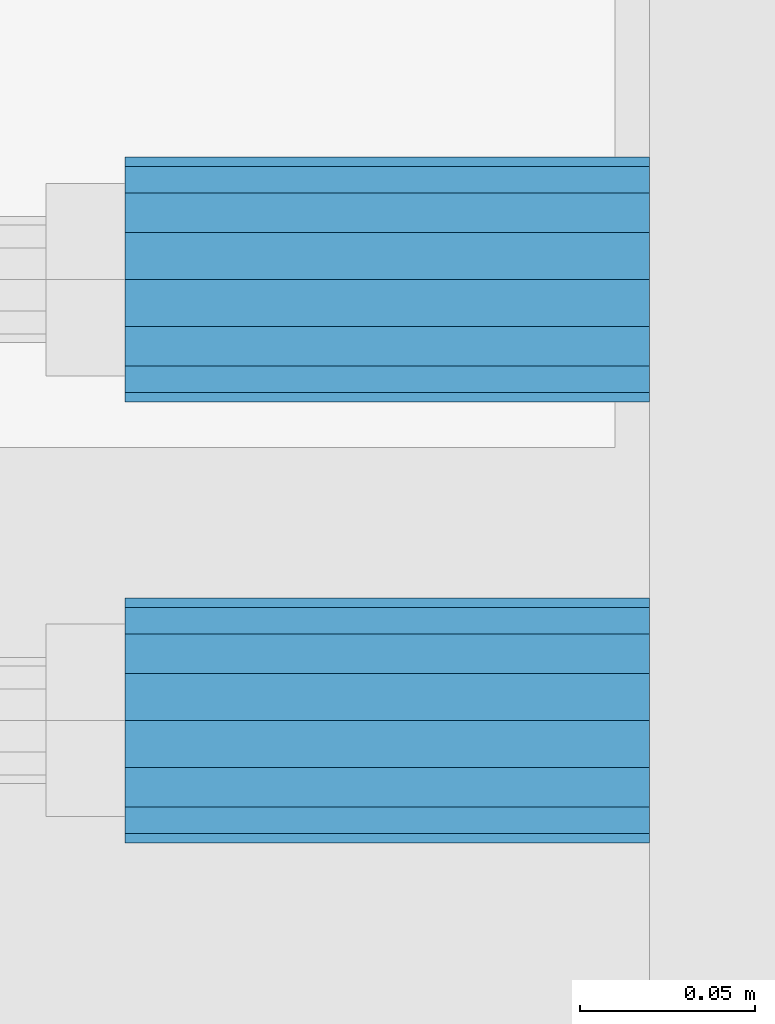
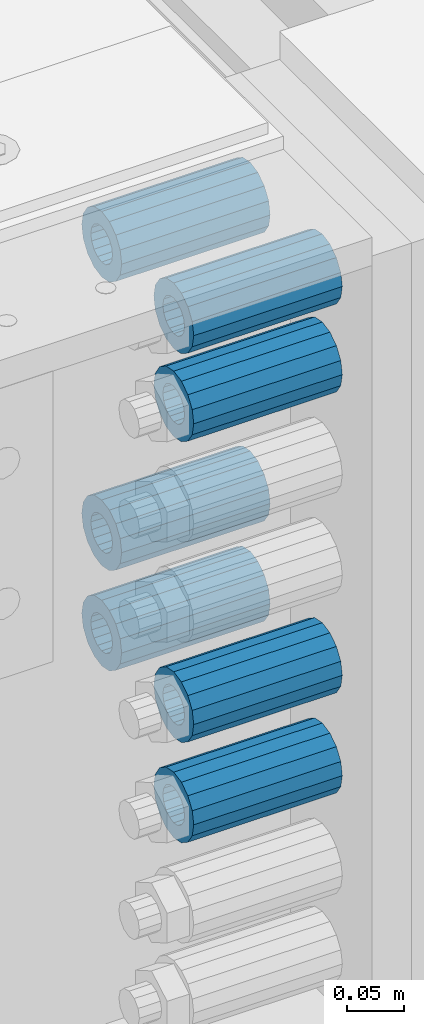
# One storey, part 160 of 257: 7 beams.
"""IFC2X3 building model written with IfcOpenShell, lengths in millimetres."""

from ifc_helpers import new_model, si_unit, frame, origin_with_axes, place, context, subcontext, project, spatial, faceted_brep, material, type_object, element, save


model = new_model("IFC2X3")

# Units and contexts
model_context = context("Model", 3, precision=1e-05, world=origin_with_axes())
body_context = subcontext(model_context, "Body", "Model", "MODEL_VIEW")
ifc_project = project(units=[si_unit("LENGTHUNIT", "METRE", prefix="MILLI"), si_unit("AREAUNIT", "SQUARE_METRE"), si_unit("VOLUMEUNIT", "CUBIC_METRE"), si_unit("MASSUNIT", "GRAM", prefix="KILO"), si_unit("TIMEUNIT", "SECOND"), si_unit("PLANEANGLEUNIT", "RADIAN"), si_unit("SOLIDANGLEUNIT", "STERADIAN"), si_unit("THERMODYNAMICTEMPERATUREUNIT", "DEGREE_CELSIUS"), si_unit("LUMINOUSINTENSITYUNIT", "LUMEN")], contexts=[model_context])

# Site, building, storey
site_placement = place(None, origin_with_axes())
site = spatial("IfcSite", under=ifc_project, at=site_placement, CompositionType="ELEMENT")
building_placement = place(site_placement, origin_with_axes())
building = spatial("IfcBuilding", under=site, at=building_placement, Name="Standard", CompositionType="ELEMENT")
storey_placement = place(building_placement, origin_with_axes())
storey = spatial("IfcBuildingStorey", under=building, at=storey_placement, Name="Undefined", CompositionType="ELEMENT", Elevation=0.0)

# Beams
ifc_material = material()
beam_type = type_object("IfcBeamType", PredefinedType="NOTDEFINED")
beam_1_placement = place(storey_placement, frame((59117.0, -63.0, -499.0), z_axis=(0.0, 0.0, 1.0), x_axis=(1.0, 0.0, 0.0)))
element("IfcBeam", 1, at=beam_1_placement, inside=storey, type_object=beam_type, material=ifc_material, context=body_context, shape_type="Brep", body=[
    faceted_brep([(-1.3120632047503e-07, -18.9999999995493, -6.27187546342611e-09), (0.0, -17.5537111177146, 7.27098521493672), (150.0, -17.5537111177146, 7.27098521493672), (150.0, -19.0, 0.0), (0.0, -13.4350288425449, 13.4350288425444), (150.0, -13.4350288425449, 13.4350288425444), (0.0, -7.27098521493645, 17.5537111177144), (150.0, -7.27098521493645, 17.5537111177144), (-6.33792751614237e-09, 4.50654624728486e-10, 18.9999999937208), (150.0, 0.0, 19.0), (0.0, 7.27098521493645, 17.5537111177144), (150.0, 7.27098521493645, 17.5537111177144), (0.0, 13.4350288425449, 13.4350288425444), (150.0, 13.4350288425449, 13.4350288425444), (0.0, 17.5537111177146, 7.2709852149367), (150.0, 17.5537111177146, 7.2709852149367), (1.33208345687308e-07, 19.0000000004507, -6.27187546342611e-09), (150.0, 19.0, 0.0), (0.0, 17.5537111177146, -7.2709852149367), (150.0, 17.5537111177146, -7.2709852149367), (0.0, 13.4350288425449, -13.4350288425444), (150.0, 13.4350288425449, -13.4350288425444), (0.0, 7.27098521493645, -17.5537111177144), (150.0, 7.27098521493645, -17.5537111177144), (8.33983904158231e-09, 4.50654624728486e-10, -19.0000000062719), (150.0, 0.0, -19.0), (0.0, -7.27098521493645, -17.5537111177144), (150.0, -7.27098521493645, -17.5537111177144), (0.0, -13.4350288425449, -13.4350288425444), (150.0, -13.4350288425449, -13.4350288425444), (0.0, -17.5537111177146, -7.2709852149367), (150.0, -17.5537111177146, -7.2709852149367), (7.27595761418343e-12, -35.0, 0.0), (1.45519152283669e-11, -32.335783637895, -13.3939201327781), (150.0, -32.3357836378955, -13.3939201327782), (150.0, -35.0, 0.0), (7.27595761418343e-12, -24.7487373415292, -24.748737341529), (150.0, -24.7487373415288, -24.7487373415292), (7.27595761418343e-12, -13.3939201327781, -32.335783637895), (150.0, -13.3939201327785, -32.335783637895), (7.27595761418343e-12, 0.0, -35.0), (150.0, 0.0, -35.0), (7.27595761418343e-12, 13.3939201327782, -32.335783637895), (150.0, 13.3939201327785, -32.335783637895), (7.27595761418343e-12, 24.7487373415292, -24.748737341529), (150.0, 24.7487373415288, -24.7487373415292), (1.45519152283669e-11, 32.335783637895, -13.3939201327781), (150.0, 32.3357836378955, -13.3939201327781), (7.27595761418343e-12, 35.0, 0.0), (150.0, 35.0, 0.0), (7.27595761418343e-12, 32.335783637895, 13.3939201327782), (150.0, 32.3357836378955, 13.3939201327781), (7.27595761418343e-12, 24.7487373415292, 24.7487373415291), (150.0, 24.7487373415288, 24.7487373415292), (1.45519152283669e-11, 13.3939201327781, 32.335783637895), (150.0, 13.3939201327785, 32.335783637895), (1.45519152283669e-11, 0.0, 35.0000000000001), (150.0, 0.0, 35.0), (1.45519152283669e-11, -13.3939201327781, 32.335783637895), (150.0, -13.3939201327785, 32.335783637895), (7.27595761418343e-12, -24.7487373415292, 24.7487373415291), (150.0, -24.7487373415288, 24.7487373415292), (7.27595761418343e-12, -32.335783637895, 13.3939201327782), (150.0, -32.3357836378955, 13.3939201327781)], [[[0, 1, 2, 3]], [[1, 4, 5, 2]], [[4, 6, 7, 5]], [[6, 8, 9, 7]], [[8, 10, 11, 9]], [[10, 12, 13, 11]], [[12, 14, 15, 13]], [[14, 16, 17, 15]], [[16, 18, 19, 17]], [[18, 20, 21, 19]], [[20, 22, 23, 21]], [[22, 24, 25, 23]], [[24, 26, 27, 25]], [[26, 28, 29, 27]], [[28, 30, 31, 29]], [[30, 0, 3, 31]], [[32, 33, 34, 35]], [[33, 36, 37, 34]], [[36, 38, 39, 37]], [[38, 40, 41, 39]], [[40, 42, 43, 41]], [[42, 44, 45, 43]], [[44, 46, 47, 45]], [[46, 48, 49, 47]], [[48, 50, 51, 49]], [[50, 52, 53, 51]], [[52, 54, 55, 53]], [[54, 56, 57, 55]], [[56, 58, 59, 57]], [[58, 60, 61, 59]], [[60, 62, 63, 61]], [[62, 32, 35, 63]], [[37, 39, 41, 43, 45, 47, 49, 51, 53, 55, 57, 59, 61, 63, 35, 34], [5, 7, 9, 11, 13, 15, 17, 19, 21, 23, 25, 27, 29, 31, 3, 2]], [[62, 60, 58, 56, 54, 52, 50, 48, 46, 44, 42, 40, 38, 36, 33, 32], [30, 28, 26, 24, 22, 20, 18, 16, 14, 12, 10, 8, 6, 4, 1, 0]]]),
])
beam_2_placement = place(storey_placement, frame((59117.0, -63.0, -84.0000000000001), z_axis=(0.0, 0.0, 1.0), x_axis=(1.0, 0.0, 0.0)))
element("IfcBeam", 2, at=beam_2_placement, inside=storey, type_object=beam_type, material=ifc_material, context=body_context, shape_type="Brep", body=[
    faceted_brep([(-1.3120632047503e-07, -18.9999999995493, -6.27187546342611e-09), (0.0, -17.5537111177146, 7.27098521493672), (150.0, -17.5537111177146, 7.27098521493672), (150.0, -19.0, 0.0), (0.0, -13.4350288425449, 13.4350288425444), (150.0, -13.4350288425449, 13.4350288425444), (0.0, -7.27098521493645, 17.5537111177144), (150.0, -7.27098521493645, 17.5537111177144), (-6.33792751614237e-09, 4.50654624728486e-10, 18.9999999937208), (150.0, 0.0, 19.0), (0.0, 7.27098521493645, 17.5537111177144), (150.0, 7.27098521493645, 17.5537111177144), (0.0, 13.4350288425449, 13.4350288425444), (150.0, 13.4350288425449, 13.4350288425444), (0.0, 17.5537111177146, 7.2709852149367), (150.0, 17.5537111177146, 7.2709852149367), (1.33208345687308e-07, 19.0000000004507, -6.27187546342611e-09), (150.0, 19.0, 0.0), (0.0, 17.5537111177146, -7.2709852149367), (150.0, 17.5537111177146, -7.2709852149367), (0.0, 13.4350288425449, -13.4350288425444), (150.0, 13.4350288425449, -13.4350288425444), (0.0, 7.27098521493645, -17.5537111177144), (150.0, 7.27098521493645, -17.5537111177144), (8.33983904158231e-09, 4.50654624728486e-10, -19.0000000062719), (150.0, 0.0, -19.0), (0.0, -7.27098521493645, -17.5537111177144), (150.0, -7.27098521493645, -17.5537111177144), (0.0, -13.4350288425449, -13.4350288425444), (150.0, -13.4350288425449, -13.4350288425444), (0.0, -17.5537111177146, -7.2709852149367), (150.0, -17.5537111177146, -7.2709852149367), (7.27595761418343e-12, -35.0, 0.0), (1.45519152283669e-11, -32.335783637895, -13.3939201327781), (150.0, -32.3357836378955, -13.3939201327782), (150.0, -35.0, 0.0), (7.27595761418343e-12, -24.7487373415292, -24.748737341529), (150.0, -24.7487373415288, -24.7487373415292), (7.27595761418343e-12, -13.3939201327781, -32.335783637895), (150.0, -13.3939201327785, -32.335783637895), (7.27595761418343e-12, 0.0, -35.0), (150.0, 0.0, -35.0), (7.27595761418343e-12, 13.3939201327782, -32.335783637895), (150.0, 13.3939201327785, -32.335783637895), (7.27595761418343e-12, 24.7487373415292, -24.748737341529), (150.0, 24.7487373415288, -24.7487373415292), (1.45519152283669e-11, 32.335783637895, -13.3939201327781), (150.0, 32.3357836378955, -13.3939201327781), (7.27595761418343e-12, 35.0, 0.0), (150.0, 35.0, 0.0), (7.27595761418343e-12, 32.335783637895, 13.3939201327782), (150.0, 32.3357836378955, 13.3939201327781), (7.27595761418343e-12, 24.7487373415292, 24.7487373415291), (150.0, 24.7487373415288, 24.7487373415292), (1.45519152283669e-11, 13.3939201327781, 32.335783637895), (150.0, 13.3939201327785, 32.335783637895), (1.45519152283669e-11, 0.0, 35.0000000000001), (150.0, 0.0, 35.0), (1.45519152283669e-11, -13.3939201327781, 32.335783637895), (150.0, -13.3939201327785, 32.335783637895), (7.27595761418343e-12, -24.7487373415292, 24.7487373415291), (150.0, -24.7487373415288, 24.7487373415292), (7.27595761418343e-12, -32.335783637895, 13.3939201327782), (150.0, -32.3357836378955, 13.3939201327781)], [[[0, 1, 2, 3]], [[1, 4, 5, 2]], [[4, 6, 7, 5]], [[6, 8, 9, 7]], [[8, 10, 11, 9]], [[10, 12, 13, 11]], [[12, 14, 15, 13]], [[14, 16, 17, 15]], [[16, 18, 19, 17]], [[18, 20, 21, 19]], [[20, 22, 23, 21]], [[22, 24, 25, 23]], [[24, 26, 27, 25]], [[26, 28, 29, 27]], [[28, 30, 31, 29]], [[30, 0, 3, 31]], [[32, 33, 34, 35]], [[33, 36, 37, 34]], [[36, 38, 39, 37]], [[38, 40, 41, 39]], [[40, 42, 43, 41]], [[42, 44, 45, 43]], [[44, 46, 47, 45]], [[46, 48, 49, 47]], [[48, 50, 51, 49]], [[50, 52, 53, 51]], [[52, 54, 55, 53]], [[54, 56, 57, 55]], [[56, 58, 59, 57]], [[58, 60, 61, 59]], [[60, 62, 63, 61]], [[62, 32, 35, 63]], [[37, 39, 41, 43, 45, 47, 49, 51, 53, 55, 57, 59, 61, 63, 35, 34], [5, 7, 9, 11, 13, 15, 17, 19, 21, 23, 25, 27, 29, 31, 3, 2]], [[62, 60, 58, 56, 54, 52, 50, 48, 46, 44, 42, 40, 38, 36, 33, 32], [30, 28, 26, 24, 22, 20, 18, 16, 14, 12, 10, 8, 6, 4, 1, 0]]]),
])
beam_3_placement = place(storey_placement, frame((59117.0, 63.0, -84.0000000000001), z_axis=(0.0, 0.0, 1.0), x_axis=(1.0, 0.0, 0.0)))
element("IfcBeam", 3, at=beam_3_placement, inside=storey, type_object=beam_type, material=ifc_material, context=body_context, shape_type="Brep", body=[
    faceted_brep([(-1.3120632047503e-07, -18.9999999995493, -6.27187546342611e-09), (0.0, -17.5537111177146, 7.27098521493672), (150.0, -17.5537111177146, 7.27098521493672), (150.0, -19.0, 0.0), (0.0, -13.4350288425449, 13.4350288425444), (150.0, -13.4350288425449, 13.4350288425444), (0.0, -7.27098521493645, 17.5537111177144), (150.0, -7.27098521493645, 17.5537111177144), (-6.33792751614237e-09, 4.50654624728486e-10, 18.9999999937208), (150.0, 0.0, 19.0), (0.0, 7.27098521493645, 17.5537111177144), (150.0, 7.27098521493645, 17.5537111177144), (0.0, 13.4350288425449, 13.4350288425444), (150.0, 13.4350288425449, 13.4350288425444), (0.0, 17.5537111177146, 7.2709852149367), (150.0, 17.5537111177146, 7.2709852149367), (1.33208345687308e-07, 19.0000000004507, -6.27187546342611e-09), (150.0, 19.0, 0.0), (0.0, 17.5537111177146, -7.2709852149367), (150.0, 17.5537111177146, -7.2709852149367), (0.0, 13.4350288425449, -13.4350288425444), (150.0, 13.4350288425449, -13.4350288425444), (0.0, 7.27098521493645, -17.5537111177144), (150.0, 7.27098521493645, -17.5537111177144), (8.33983904158231e-09, 4.50654624728486e-10, -19.0000000062719), (150.0, 0.0, -19.0), (0.0, -7.27098521493645, -17.5537111177144), (150.0, -7.27098521493645, -17.5537111177144), (0.0, -13.4350288425449, -13.4350288425444), (150.0, -13.4350288425449, -13.4350288425444), (0.0, -17.5537111177146, -7.2709852149367), (150.0, -17.5537111177146, -7.2709852149367), (7.27595761418343e-12, -35.0, 0.0), (1.45519152283669e-11, -32.335783637895, -13.3939201327781), (150.0, -32.3357836378955, -13.3939201327782), (150.0, -35.0, 0.0), (7.27595761418343e-12, -24.7487373415292, -24.748737341529), (150.0, -24.7487373415288, -24.7487373415292), (7.27595761418343e-12, -13.3939201327781, -32.335783637895), (150.0, -13.3939201327785, -32.335783637895), (7.27595761418343e-12, 0.0, -35.0), (150.0, 0.0, -35.0), (7.27595761418343e-12, 13.3939201327782, -32.335783637895), (150.0, 13.3939201327785, -32.335783637895), (7.27595761418343e-12, 24.7487373415292, -24.748737341529), (150.0, 24.7487373415288, -24.7487373415292), (1.45519152283669e-11, 32.335783637895, -13.3939201327781), (150.0, 32.3357836378955, -13.3939201327781), (7.27595761418343e-12, 35.0, 0.0), (150.0, 35.0, 0.0), (7.27595761418343e-12, 32.335783637895, 13.3939201327782), (150.0, 32.3357836378955, 13.3939201327781), (7.27595761418343e-12, 24.7487373415292, 24.7487373415291), (150.0, 24.7487373415288, 24.7487373415292), (1.45519152283669e-11, 13.3939201327781, 32.335783637895), (150.0, 13.3939201327785, 32.335783637895), (1.45519152283669e-11, 0.0, 35.0000000000001), (150.0, 0.0, 35.0), (1.45519152283669e-11, -13.3939201327781, 32.335783637895), (150.0, -13.3939201327785, 32.335783637895), (7.27595761418343e-12, -24.7487373415292, 24.7487373415291), (150.0, -24.7487373415288, 24.7487373415292), (7.27595761418343e-12, -32.335783637895, 13.3939201327782), (150.0, -32.3357836378955, 13.3939201327781)], [[[0, 1, 2, 3]], [[1, 4, 5, 2]], [[4, 6, 7, 5]], [[6, 8, 9, 7]], [[8, 10, 11, 9]], [[10, 12, 13, 11]], [[12, 14, 15, 13]], [[14, 16, 17, 15]], [[16, 18, 19, 17]], [[18, 20, 21, 19]], [[20, 22, 23, 21]], [[22, 24, 25, 23]], [[24, 26, 27, 25]], [[26, 28, 29, 27]], [[28, 30, 31, 29]], [[30, 0, 3, 31]], [[32, 33, 34, 35]], [[33, 36, 37, 34]], [[36, 38, 39, 37]], [[38, 40, 41, 39]], [[40, 42, 43, 41]], [[42, 44, 45, 43]], [[44, 46, 47, 45]], [[46, 48, 49, 47]], [[48, 50, 51, 49]], [[50, 52, 53, 51]], [[52, 54, 55, 53]], [[54, 56, 57, 55]], [[56, 58, 59, 57]], [[58, 60, 61, 59]], [[60, 62, 63, 61]], [[62, 32, 35, 63]], [[37, 39, 41, 43, 45, 47, 49, 51, 53, 55, 57, 59, 61, 63, 35, 34], [5, 7, 9, 11, 13, 15, 17, 19, 21, 23, 25, 27, 29, 31, 3, 2]], [[62, 60, 58, 56, 54, 52, 50, 48, 46, 44, 42, 40, 38, 36, 33, 32], [30, 28, 26, 24, 22, 20, 18, 16, 14, 12, 10, 8, 6, 4, 1, 0]]]),
])
beam_4_placement = place(storey_placement, frame((59117.0, -63.0, -606.0), z_axis=(0.0, 0.0, 1.0), x_axis=(1.0, 0.0, 0.0)))
element("IfcBeam", 4, at=beam_4_placement, inside=storey, type_object=beam_type, material=ifc_material, context=body_context, shape_type="Brep", body=[
    faceted_brep([(-1.3120632047503e-07, -18.9999999995493, -6.27187546342611e-09), (0.0, -17.5537111177146, 7.27098521493672), (150.0, -17.5537111177146, 7.27098521493672), (150.0, -19.0, 0.0), (0.0, -13.4350288425449, 13.4350288425444), (150.0, -13.4350288425449, 13.4350288425444), (0.0, -7.27098521493645, 17.5537111177144), (150.0, -7.27098521493645, 17.5537111177144), (-6.33792751614237e-09, 4.50654624728486e-10, 18.9999999937208), (150.0, 0.0, 19.0), (0.0, 7.27098521493645, 17.5537111177144), (150.0, 7.27098521493645, 17.5537111177144), (0.0, 13.4350288425449, 13.4350288425444), (150.0, 13.4350288425449, 13.4350288425444), (0.0, 17.5537111177146, 7.2709852149367), (150.0, 17.5537111177146, 7.2709852149367), (1.33208345687308e-07, 19.0000000004507, -6.27187546342611e-09), (150.0, 19.0, 0.0), (0.0, 17.5537111177146, -7.2709852149367), (150.0, 17.5537111177146, -7.2709852149367), (0.0, 13.4350288425449, -13.4350288425444), (150.0, 13.4350288425449, -13.4350288425444), (0.0, 7.27098521493645, -17.5537111177144), (150.0, 7.27098521493645, -17.5537111177144), (8.33983904158231e-09, 4.50654624728486e-10, -19.0000000062719), (150.0, 0.0, -19.0), (0.0, -7.27098521493645, -17.5537111177144), (150.0, -7.27098521493645, -17.5537111177144), (0.0, -13.4350288425449, -13.4350288425444), (150.0, -13.4350288425449, -13.4350288425444), (0.0, -17.5537111177146, -7.2709852149367), (150.0, -17.5537111177146, -7.2709852149367), (7.27595761418343e-12, -35.0, 0.0), (1.45519152283669e-11, -32.335783637895, -13.3939201327781), (150.0, -32.3357836378955, -13.3939201327782), (150.0, -35.0, 0.0), (7.27595761418343e-12, -24.7487373415292, -24.748737341529), (150.0, -24.7487373415288, -24.7487373415292), (7.27595761418343e-12, -13.3939201327781, -32.335783637895), (150.0, -13.3939201327785, -32.335783637895), (7.27595761418343e-12, 0.0, -35.0), (150.0, 0.0, -35.0), (7.27595761418343e-12, 13.3939201327782, -32.335783637895), (150.0, 13.3939201327785, -32.335783637895), (7.27595761418343e-12, 24.7487373415292, -24.748737341529), (150.0, 24.7487373415288, -24.7487373415292), (1.45519152283669e-11, 32.335783637895, -13.3939201327781), (150.0, 32.3357836378955, -13.3939201327781), (7.27595761418343e-12, 35.0, 0.0), (150.0, 35.0, 0.0), (7.27595761418343e-12, 32.335783637895, 13.3939201327782), (150.0, 32.3357836378955, 13.3939201327781), (7.27595761418343e-12, 24.7487373415292, 24.7487373415291), (150.0, 24.7487373415288, 24.7487373415292), (1.45519152283669e-11, 13.3939201327781, 32.335783637895), (150.0, 13.3939201327785, 32.335783637895), (1.45519152283669e-11, 0.0, 35.0000000000001), (150.0, 0.0, 35.0), (1.45519152283669e-11, -13.3939201327781, 32.335783637895), (150.0, -13.3939201327785, 32.335783637895), (7.27595761418343e-12, -24.7487373415292, 24.7487373415291), (150.0, -24.7487373415288, 24.7487373415292), (7.27595761418343e-12, -32.335783637895, 13.3939201327782), (150.0, -32.3357836378955, 13.3939201327781)], [[[0, 1, 2, 3]], [[1, 4, 5, 2]], [[4, 6, 7, 5]], [[6, 8, 9, 7]], [[8, 10, 11, 9]], [[10, 12, 13, 11]], [[12, 14, 15, 13]], [[14, 16, 17, 15]], [[16, 18, 19, 17]], [[18, 20, 21, 19]], [[20, 22, 23, 21]], [[22, 24, 25, 23]], [[24, 26, 27, 25]], [[26, 28, 29, 27]], [[28, 30, 31, 29]], [[30, 0, 3, 31]], [[32, 33, 34, 35]], [[33, 36, 37, 34]], [[36, 38, 39, 37]], [[38, 40, 41, 39]], [[40, 42, 43, 41]], [[42, 44, 45, 43]], [[44, 46, 47, 45]], [[46, 48, 49, 47]], [[48, 50, 51, 49]], [[50, 52, 53, 51]], [[52, 54, 55, 53]], [[54, 56, 57, 55]], [[56, 58, 59, 57]], [[58, 60, 61, 59]], [[60, 62, 63, 61]], [[62, 32, 35, 63]], [[37, 39, 41, 43, 45, 47, 49, 51, 53, 55, 57, 59, 61, 63, 35, 34], [5, 7, 9, 11, 13, 15, 17, 19, 21, 23, 25, 27, 29, 31, 3, 2]], [[62, 60, 58, 56, 54, 52, 50, 48, 46, 44, 42, 40, 38, 36, 33, 32], [30, 28, 26, 24, 22, 20, 18, 16, 14, 12, 10, 8, 6, 4, 1, 0]]]),
])
beam_5_placement = place(storey_placement, frame((59117.0, -63.0, -178.0), z_axis=(0.0, 0.0, 1.0), x_axis=(1.0, 0.0, 0.0)))
element("IfcBeam", 5, at=beam_5_placement, inside=storey, type_object=beam_type, material=ifc_material, context=body_context, shape_type="Brep", body=[
    faceted_brep([(-1.3120632047503e-07, -18.9999999995493, -6.27187546342611e-09), (0.0, -17.5537111177146, 7.27098521493672), (150.0, -17.5537111177146, 7.27098521493672), (150.0, -19.0, 0.0), (0.0, -13.4350288425449, 13.4350288425444), (150.0, -13.4350288425449, 13.4350288425444), (0.0, -7.27098521493645, 17.5537111177144), (150.0, -7.27098521493645, 17.5537111177144), (-6.33792751614237e-09, 4.50654624728486e-10, 18.9999999937208), (150.0, 0.0, 19.0), (0.0, 7.27098521493645, 17.5537111177144), (150.0, 7.27098521493645, 17.5537111177144), (0.0, 13.4350288425449, 13.4350288425444), (150.0, 13.4350288425449, 13.4350288425444), (0.0, 17.5537111177146, 7.2709852149367), (150.0, 17.5537111177146, 7.2709852149367), (1.33208345687308e-07, 19.0000000004507, -6.27187546342611e-09), (150.0, 19.0, 0.0), (0.0, 17.5537111177146, -7.2709852149367), (150.0, 17.5537111177146, -7.2709852149367), (0.0, 13.4350288425449, -13.4350288425444), (150.0, 13.4350288425449, -13.4350288425444), (0.0, 7.27098521493645, -17.5537111177144), (150.0, 7.27098521493645, -17.5537111177144), (8.33983904158231e-09, 4.50654624728486e-10, -19.0000000062719), (150.0, 0.0, -19.0), (0.0, -7.27098521493645, -17.5537111177144), (150.0, -7.27098521493645, -17.5537111177144), (0.0, -13.4350288425449, -13.4350288425444), (150.0, -13.4350288425449, -13.4350288425444), (0.0, -17.5537111177146, -7.2709852149367), (150.0, -17.5537111177146, -7.2709852149367), (7.27595761418343e-12, -35.0, 0.0), (1.45519152283669e-11, -32.335783637895, -13.3939201327781), (150.0, -32.3357836378955, -13.3939201327782), (150.0, -35.0, 0.0), (7.27595761418343e-12, -24.7487373415292, -24.748737341529), (150.0, -24.7487373415288, -24.7487373415292), (7.27595761418343e-12, -13.3939201327781, -32.335783637895), (150.0, -13.3939201327785, -32.335783637895), (7.27595761418343e-12, 0.0, -35.0), (150.0, 0.0, -35.0), (7.27595761418343e-12, 13.3939201327782, -32.335783637895), (150.0, 13.3939201327785, -32.335783637895), (7.27595761418343e-12, 24.7487373415292, -24.748737341529), (150.0, 24.7487373415288, -24.7487373415292), (1.45519152283669e-11, 32.335783637895, -13.3939201327781), (150.0, 32.3357836378955, -13.3939201327781), (7.27595761418343e-12, 35.0, 0.0), (150.0, 35.0, 0.0), (7.27595761418343e-12, 32.335783637895, 13.3939201327782), (150.0, 32.3357836378955, 13.3939201327781), (7.27595761418343e-12, 24.7487373415292, 24.7487373415291), (150.0, 24.7487373415288, 24.7487373415292), (1.45519152283669e-11, 13.3939201327781, 32.335783637895), (150.0, 13.3939201327785, 32.335783637895), (1.45519152283669e-11, 0.0, 35.0000000000001), (150.0, 0.0, 35.0), (1.45519152283669e-11, -13.3939201327781, 32.335783637895), (150.0, -13.3939201327785, 32.335783637895), (7.27595761418343e-12, -24.7487373415292, 24.7487373415291), (150.0, -24.7487373415288, 24.7487373415292), (7.27595761418343e-12, -32.335783637895, 13.3939201327782), (150.0, -32.3357836378955, 13.3939201327781)], [[[0, 1, 2, 3]], [[1, 4, 5, 2]], [[4, 6, 7, 5]], [[6, 8, 9, 7]], [[8, 10, 11, 9]], [[10, 12, 13, 11]], [[12, 14, 15, 13]], [[14, 16, 17, 15]], [[16, 18, 19, 17]], [[18, 20, 21, 19]], [[20, 22, 23, 21]], [[22, 24, 25, 23]], [[24, 26, 27, 25]], [[26, 28, 29, 27]], [[28, 30, 31, 29]], [[30, 0, 3, 31]], [[32, 33, 34, 35]], [[33, 36, 37, 34]], [[36, 38, 39, 37]], [[38, 40, 41, 39]], [[40, 42, 43, 41]], [[42, 44, 45, 43]], [[44, 46, 47, 45]], [[46, 48, 49, 47]], [[48, 50, 51, 49]], [[50, 52, 53, 51]], [[52, 54, 55, 53]], [[54, 56, 57, 55]], [[56, 58, 59, 57]], [[58, 60, 61, 59]], [[60, 62, 63, 61]], [[62, 32, 35, 63]], [[37, 39, 41, 43, 45, 47, 49, 51, 53, 55, 57, 59, 61, 63, 35, 34], [5, 7, 9, 11, 13, 15, 17, 19, 21, 23, 25, 27, 29, 31, 3, 2]], [[62, 60, 58, 56, 54, 52, 50, 48, 46, 44, 42, 40, 38, 36, 33, 32], [30, 28, 26, 24, 22, 20, 18, 16, 14, 12, 10, 8, 6, 4, 1, 0]]]),
])
beam_6_placement = place(storey_placement, frame((59117.0, 63.0, -499.0), z_axis=(0.0, 0.0, 1.0), x_axis=(1.0, 0.0, 0.0)))
element("IfcBeam", 6, at=beam_6_placement, inside=storey, type_object=beam_type, material=ifc_material, context=body_context, shape_type="Brep", body=[
    faceted_brep([(-1.3120632047503e-07, -18.9999999995493, -6.27187546342611e-09), (0.0, -17.5537111177146, 7.27098521493672), (150.0, -17.5537111177146, 7.27098521493672), (150.0, -19.0, 0.0), (0.0, -13.4350288425449, 13.4350288425444), (150.0, -13.4350288425449, 13.4350288425444), (0.0, -7.27098521493645, 17.5537111177144), (150.0, -7.27098521493645, 17.5537111177144), (-6.33792751614237e-09, 4.50654624728486e-10, 18.9999999937208), (150.0, 0.0, 19.0), (0.0, 7.27098521493645, 17.5537111177144), (150.0, 7.27098521493645, 17.5537111177144), (0.0, 13.4350288425449, 13.4350288425444), (150.0, 13.4350288425449, 13.4350288425444), (0.0, 17.5537111177146, 7.2709852149367), (150.0, 17.5537111177146, 7.2709852149367), (1.33208345687308e-07, 19.0000000004507, -6.27187546342611e-09), (150.0, 19.0, 0.0), (0.0, 17.5537111177146, -7.2709852149367), (150.0, 17.5537111177146, -7.2709852149367), (0.0, 13.4350288425449, -13.4350288425444), (150.0, 13.4350288425449, -13.4350288425444), (0.0, 7.27098521493645, -17.5537111177144), (150.0, 7.27098521493645, -17.5537111177144), (8.33983904158231e-09, 4.50654624728486e-10, -19.0000000062719), (150.0, 0.0, -19.0), (0.0, -7.27098521493645, -17.5537111177144), (150.0, -7.27098521493645, -17.5537111177144), (0.0, -13.4350288425449, -13.4350288425444), (150.0, -13.4350288425449, -13.4350288425444), (0.0, -17.5537111177146, -7.2709852149367), (150.0, -17.5537111177146, -7.2709852149367), (7.27595761418343e-12, -35.0, 0.0), (1.45519152283669e-11, -32.335783637895, -13.3939201327781), (150.0, -32.3357836378955, -13.3939201327782), (150.0, -35.0, 0.0), (7.27595761418343e-12, -24.7487373415292, -24.748737341529), (150.0, -24.7487373415288, -24.7487373415292), (7.27595761418343e-12, -13.3939201327781, -32.335783637895), (150.0, -13.3939201327785, -32.335783637895), (7.27595761418343e-12, 0.0, -35.0), (150.0, 0.0, -35.0), (7.27595761418343e-12, 13.3939201327782, -32.335783637895), (150.0, 13.3939201327785, -32.335783637895), (7.27595761418343e-12, 24.7487373415292, -24.748737341529), (150.0, 24.7487373415288, -24.7487373415292), (1.45519152283669e-11, 32.335783637895, -13.3939201327781), (150.0, 32.3357836378955, -13.3939201327781), (7.27595761418343e-12, 35.0, 0.0), (150.0, 35.0, 0.0), (7.27595761418343e-12, 32.335783637895, 13.3939201327782), (150.0, 32.3357836378955, 13.3939201327781), (7.27595761418343e-12, 24.7487373415292, 24.7487373415291), (150.0, 24.7487373415288, 24.7487373415292), (1.45519152283669e-11, 13.3939201327781, 32.335783637895), (150.0, 13.3939201327785, 32.335783637895), (1.45519152283669e-11, 0.0, 35.0000000000001), (150.0, 0.0, 35.0), (1.45519152283669e-11, -13.3939201327781, 32.335783637895), (150.0, -13.3939201327785, 32.335783637895), (7.27595761418343e-12, -24.7487373415292, 24.7487373415291), (150.0, -24.7487373415288, 24.7487373415292), (7.27595761418343e-12, -32.335783637895, 13.3939201327782), (150.0, -32.3357836378955, 13.3939201327781)], [[[0, 1, 2, 3]], [[1, 4, 5, 2]], [[4, 6, 7, 5]], [[6, 8, 9, 7]], [[8, 10, 11, 9]], [[10, 12, 13, 11]], [[12, 14, 15, 13]], [[14, 16, 17, 15]], [[16, 18, 19, 17]], [[18, 20, 21, 19]], [[20, 22, 23, 21]], [[22, 24, 25, 23]], [[24, 26, 27, 25]], [[26, 28, 29, 27]], [[28, 30, 31, 29]], [[30, 0, 3, 31]], [[32, 33, 34, 35]], [[33, 36, 37, 34]], [[36, 38, 39, 37]], [[38, 40, 41, 39]], [[40, 42, 43, 41]], [[42, 44, 45, 43]], [[44, 46, 47, 45]], [[46, 48, 49, 47]], [[48, 50, 51, 49]], [[50, 52, 53, 51]], [[52, 54, 55, 53]], [[54, 56, 57, 55]], [[56, 58, 59, 57]], [[58, 60, 61, 59]], [[60, 62, 63, 61]], [[62, 32, 35, 63]], [[37, 39, 41, 43, 45, 47, 49, 51, 53, 55, 57, 59, 61, 63, 35, 34], [5, 7, 9, 11, 13, 15, 17, 19, 21, 23, 25, 27, 29, 31, 3, 2]], [[62, 60, 58, 56, 54, 52, 50, 48, 46, 44, 42, 40, 38, 36, 33, 32], [30, 28, 26, 24, 22, 20, 18, 16, 14, 12, 10, 8, 6, 4, 1, 0]]]),
])
beam_7_placement = place(storey_placement, frame((59117.0, 63.0, -392.0), z_axis=(0.0, 0.0, 1.0), x_axis=(1.0, 0.0, 0.0)))
element("IfcBeam", 7, at=beam_7_placement, inside=storey, type_object=beam_type, material=ifc_material, context=body_context, shape_type="Brep", body=[
    faceted_brep([(-1.3120632047503e-07, -18.9999999995493, -6.27187546342611e-09), (0.0, -17.5537111177146, 7.27098521493672), (150.0, -17.5537111177146, 7.27098521493672), (150.0, -19.0, 0.0), (0.0, -13.4350288425449, 13.4350288425444), (150.0, -13.4350288425449, 13.4350288425444), (0.0, -7.27098521493645, 17.5537111177144), (150.0, -7.27098521493645, 17.5537111177144), (-6.33792751614237e-09, 4.50654624728486e-10, 18.9999999937208), (150.0, 0.0, 19.0), (0.0, 7.27098521493645, 17.5537111177144), (150.0, 7.27098521493645, 17.5537111177144), (0.0, 13.4350288425449, 13.4350288425444), (150.0, 13.4350288425449, 13.4350288425444), (0.0, 17.5537111177146, 7.2709852149367), (150.0, 17.5537111177146, 7.2709852149367), (1.33208345687308e-07, 19.0000000004507, -6.27187546342611e-09), (150.0, 19.0, 0.0), (0.0, 17.5537111177146, -7.2709852149367), (150.0, 17.5537111177146, -7.2709852149367), (0.0, 13.4350288425449, -13.4350288425444), (150.0, 13.4350288425449, -13.4350288425444), (0.0, 7.27098521493645, -17.5537111177144), (150.0, 7.27098521493645, -17.5537111177144), (8.33983904158231e-09, 4.50654624728486e-10, -19.0000000062719), (150.0, 0.0, -19.0), (0.0, -7.27098521493645, -17.5537111177144), (150.0, -7.27098521493645, -17.5537111177144), (0.0, -13.4350288425449, -13.4350288425444), (150.0, -13.4350288425449, -13.4350288425444), (0.0, -17.5537111177146, -7.2709852149367), (150.0, -17.5537111177146, -7.2709852149367), (7.27595761418343e-12, -35.0, 0.0), (1.45519152283669e-11, -32.335783637895, -13.3939201327781), (150.0, -32.3357836378955, -13.3939201327782), (150.0, -35.0, 0.0), (7.27595761418343e-12, -24.7487373415292, -24.748737341529), (150.0, -24.7487373415288, -24.7487373415292), (7.27595761418343e-12, -13.3939201327781, -32.335783637895), (150.0, -13.3939201327785, -32.335783637895), (7.27595761418343e-12, 0.0, -35.0), (150.0, 0.0, -35.0), (7.27595761418343e-12, 13.3939201327782, -32.335783637895), (150.0, 13.3939201327785, -32.335783637895), (7.27595761418343e-12, 24.7487373415292, -24.748737341529), (150.0, 24.7487373415288, -24.7487373415292), (1.45519152283669e-11, 32.335783637895, -13.3939201327781), (150.0, 32.3357836378955, -13.3939201327781), (7.27595761418343e-12, 35.0, 0.0), (150.0, 35.0, 0.0), (7.27595761418343e-12, 32.335783637895, 13.3939201327782), (150.0, 32.3357836378955, 13.3939201327781), (7.27595761418343e-12, 24.7487373415292, 24.7487373415291), (150.0, 24.7487373415288, 24.7487373415292), (1.45519152283669e-11, 13.3939201327781, 32.335783637895), (150.0, 13.3939201327785, 32.335783637895), (1.45519152283669e-11, 0.0, 35.0000000000001), (150.0, 0.0, 35.0), (1.45519152283669e-11, -13.3939201327781, 32.335783637895), (150.0, -13.3939201327785, 32.335783637895), (7.27595761418343e-12, -24.7487373415292, 24.7487373415291), (150.0, -24.7487373415288, 24.7487373415292), (7.27595761418343e-12, -32.335783637895, 13.3939201327782), (150.0, -32.3357836378955, 13.3939201327781)], [[[0, 1, 2, 3]], [[1, 4, 5, 2]], [[4, 6, 7, 5]], [[6, 8, 9, 7]], [[8, 10, 11, 9]], [[10, 12, 13, 11]], [[12, 14, 15, 13]], [[14, 16, 17, 15]], [[16, 18, 19, 17]], [[18, 20, 21, 19]], [[20, 22, 23, 21]], [[22, 24, 25, 23]], [[24, 26, 27, 25]], [[26, 28, 29, 27]], [[28, 30, 31, 29]], [[30, 0, 3, 31]], [[32, 33, 34, 35]], [[33, 36, 37, 34]], [[36, 38, 39, 37]], [[38, 40, 41, 39]], [[40, 42, 43, 41]], [[42, 44, 45, 43]], [[44, 46, 47, 45]], [[46, 48, 49, 47]], [[48, 50, 51, 49]], [[50, 52, 53, 51]], [[52, 54, 55, 53]], [[54, 56, 57, 55]], [[56, 58, 59, 57]], [[58, 60, 61, 59]], [[60, 62, 63, 61]], [[62, 32, 35, 63]], [[37, 39, 41, 43, 45, 47, 49, 51, 53, 55, 57, 59, 61, 63, 35, 34], [5, 7, 9, 11, 13, 15, 17, 19, 21, 23, 25, 27, 29, 31, 3, 2]], [[62, 60, 58, 56, 54, 52, 50, 48, 46, 44, 42, 40, 38, 36, 33, 32], [30, 28, 26, 24, 22, 20, 18, 16, 14, 12, 10, 8, 6, 4, 1, 0]]]),
])

save(model, "model.ifc")
